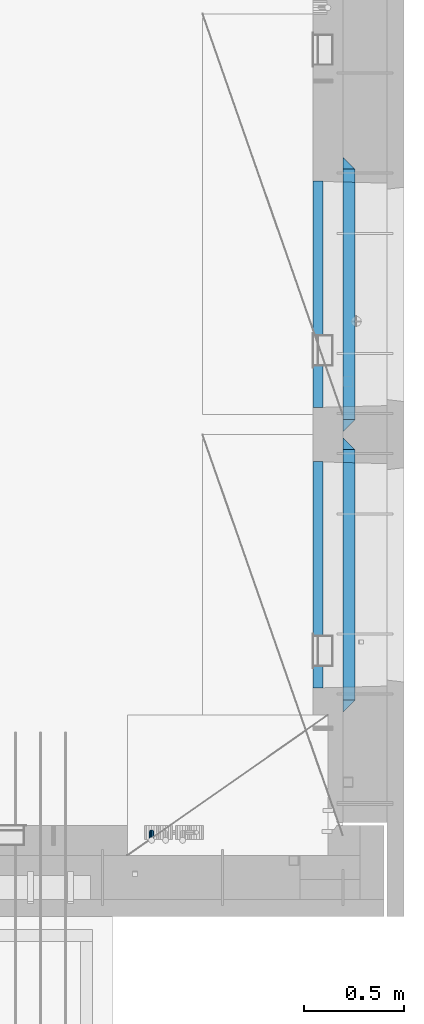
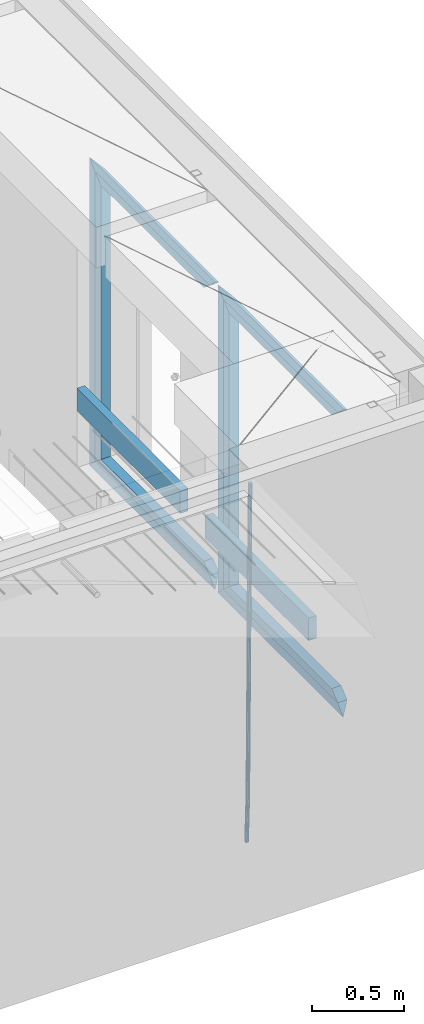
# One storey, part 131 of 350: 15 beams, 2 elements without a shape of their own.
"""IFC2X3 building model written with IfcOpenShell, lengths in millimetres."""

from ifc_helpers import new_model, si_unit, frame, origin_with_axes, place, context, subcontext, project, spatial, faceted_brep, material, type_object, element, aggregate, save


model = new_model("IFC2X3")

# Units and contexts
model_context = context("Model", 3, precision=1e-05, world=origin_with_axes())
body_context = subcontext(model_context, "Body", "Model", "MODEL_VIEW")
ifc_project = project(units=[si_unit("LENGTHUNIT", "METRE", prefix="MILLI"), si_unit("AREAUNIT", "SQUARE_METRE"), si_unit("VOLUMEUNIT", "CUBIC_METRE"), si_unit("MASSUNIT", "GRAM", prefix="KILO"), si_unit("TIMEUNIT", "SECOND"), si_unit("PLANEANGLEUNIT", "RADIAN"), si_unit("SOLIDANGLEUNIT", "STERADIAN"), si_unit("THERMODYNAMICTEMPERATUREUNIT", "DEGREE_CELSIUS"), si_unit("LUMINOUSINTENSITYUNIT", "LUMEN")], contexts=[model_context])

# Site, building, storey
site_placement = place(None, origin_with_axes())
site = spatial("IfcSite", under=ifc_project, at=site_placement, CompositionType="ELEMENT")
building_placement = place(site_placement, origin_with_axes())
building = spatial("IfcBuilding", under=site, at=building_placement, CompositionType="ELEMENT")
storey_placement = place(building_placement, origin_with_axes())
storey = spatial("IfcBuildingStorey", under=building, at=storey_placement, Name="2", CompositionType="ELEMENT", Elevation=0.0)

# Assembly, beam
assembly_1_placement = place(storey_placement, origin_with_axes())
assembly_1 = element("IfcElementAssembly", 1, at=assembly_1_placement, inside=storey, AssemblyPlace="NOTDEFINED", PredefinedType="REINFORCEMENT_UNIT")
ifc_material_1 = material()
beam_type_1 = type_object("IfcBeamType", Name="D25", PredefinedType="NOTDEFINED")
beam_1_placement = place(assembly_1_placement, frame((34104.9999999961, 7965.00000227913, 84990.0), z_axis=(0.00020576299992186, -0.999642804629538, -0.0267249099901004), x_axis=(-4.30000201928125e-08, -0.0267249099948059, 0.999642825806181)))
beam_1 = element("IfcBeam", 2, at=beam_1_placement, type_object=beam_type_1, material=ifc_material_1, Name="JM25", ObjectType="D25", context=body_context, shape_type="Brep", body=[
    faceted_brep([(-7.41420080885291e-08, -12.5, -3.63797880709171e-12), (-6.42030499875546e-08, -10.8253175473074, -6.25000000000364), (60.4103898235917, -10.8253175318459, -6.2499999938409), (60.4103898269532, -12.4999999845422, 6.16273609921336e-09), (-3.70782800018787e-08, -6.25000000000364, -10.8253175473074), (60.4103898202884, -6.24999998454587, -10.8253175411446), (-1.45519152283669e-11, -3.63797880709171e-12, -12.5), (60.4103898179019, 1.54577719513327e-08, -12.4999999938373), (3.70637280866504e-08, 6.25, -10.8253175473074), (60.410389817087, 6.25000001545777, -10.825317541141), (6.42030499875546e-08, 10.8253175473001, -6.25000000000364), (60.410389818062, 10.8253175627578, -6.24999999383726), (7.41420080885291e-08, 12.4999999999927, 0.0), (60.4103898205503, 12.5000000154541, 6.16273609921336e-09), (6.42176019027829e-08, 10.8253175473001, 6.24999999999636), (60.4103898238973, 10.8253175627651, 6.2500000061591), (3.70928319171071e-08, 6.24999999999636, 10.8253175473037), (60.4103898272151, 6.25000001546141, 10.8253175534664), (1.45519152283669e-11, -3.63797880709171e-12, 12.4999999999964), (60.4103898296162, 1.54541339725256e-08, 12.5000000061591), (-3.7049176171422e-08, -6.25000000000364, 10.8253175473001), (60.4103898304165, -6.24999998454587, 10.8253175534701), (-6.41884980723262e-08, -10.8253175473074, 6.25), (60.4103898294561, -10.8253175318459, 6.25000000616637), (61.0324985728803, -10.8253175316895, -6.24999999377542), (60.991802792938, -12.4999999843931, 6.22458173893392e-09), (61.0622854283865, -6.24999998437852, -10.8253175410755), (61.0731819955545, 1.5628756955266e-08, -12.4999999937718), (61.0622685480339, 6.25000001562512, -10.8253175410791), (61.032469335245, 10.8253175629216, -6.24999999377178), (60.9917690322181, 12.5000000156033, 6.22458173893392e-09), (60.9510732522613, 10.8253175629034, 6.25000000621731), (60.9212863967696, 6.25000001558874, 10.8253175535247), (60.9103898296162, 1.55814632307738e-08, 12.5000000062137), (60.9213032771368, -6.24999998441126, 10.8253175535174), (60.9511024898966, -10.8253175317113, 6.25000000621731), (61.6545545670233, -10.8253158516927, -6.24189838219536), (61.573166454793, -12.499998414296, 0.00757164385504439), (61.7141257553885, -6.24999822394238, -10.8168280205282), (61.7359179680789, 1.80548886419274e-06, -12.491368569139), (61.7140919992817, 6.25000177601396, -10.8168282403167), (61.6544960997562, 10.8253192428383, -6.2418987628771), (61.5730989426083, 12.5000015856094, 0.0075712042817031), (61.4917108303925, 10.8253190230062, 6.25704123032847), (61.4321396420273, 6.25000139525582, 10.8319708686649), (61.4103474293224, 1.36582457344048e-06, 12.5065114172721), (61.4321733981196, -6.24999860470052, 10.8319710884571), (61.4917692976451, -10.8253160715249, 6.25704161101385), (176.524302641745, -10.8250056210964, -4.74584321979273), (176.442914529529, -12.4996881836996, 1.50362680625403), (176.583873830095, -6.24968799334965, -9.3207728581292), (176.605666042786, 0.000312036081595579, -10.9953134067364), (176.583840074018, 6.25031200660669, -9.32077307791769), (176.524244174492, 10.8256294734347, -4.74584360047811), (176.44284701733, 12.5003118162058, 1.50362636668069), (176.361458905099, 10.8256292535989, 7.75309639272746), (176.301887716749, 6.25031162585219, 12.3280260310676), (176.280095504058, 0.000311596420942806, 14.0025665796711), (176.301921472827, -6.24968837410415, 12.3280262508561), (176.361517372367, -10.8250058409321, 7.75309677341284), (177.085397012124, -10.8250041057399, -4.73853556792164), (176.983633547483, -12.4996867233749, 1.51066909103247), (177.159881729676, -6.24968643771717, -9.31327097355097), (177.187129580227, 0.000313606451527448, -10.987740468332), (177.159839524218, 6.25031356221734, -9.31327130338468), (177.085323910098, 10.8256309887511, -4.73853613920801), (176.983549136537, 12.5003132764905, 1.51066843136869), (176.881785671867, 10.8256306588555, 7.7598730903228), (176.80730095433, 6.25031299082912, 12.3346084959521), (176.780053103794, 0.000312946667690994, 14.0090779907332), (176.807343159802, -6.2496870091054, 12.3346088257895), (176.881858773908, -10.8250044356355, 7.7598736616128), (177.646431799818, -10.8250018318176, -4.72756919822132), (177.524295146417, -12.4996845320202, 1.52123723245313), (177.735828462886, -6.24968410334986, -9.30201312475765), (177.768531371941, 0.00031596292683389, -10.9763759912421), (177.735777808921, 6.25031589654827, -9.30201361973741), (177.646344064575, 10.8256332626152, -4.72757005553649), (177.524193838486, 12.5003154677688, 1.52123624250817), (177.402057185071, 10.8256327675663, 7.77004267317898), (177.312660521988, 6.2503150390985, 12.3444865997226), (177.279957612933, 0.00031497282179771, 14.0188494661961), (177.312711175953, -6.24968496079964, 12.3444870946951), (177.402144920314, -10.8250023268702, 7.77004353049415), (299.377443161706, -10.8245084454466, -2.34813158632096), (299.255306508276, -12.4991911456491, 3.90067484435349), (299.466839824803, -6.24919071697514, -6.92257551286093), (299.499542733873, 0.0008093492979242, -8.59693837933446), (299.466789170867, 6.250809282923, -6.92257600783341), (299.377355426492, 10.8261266489935, -2.34813244364341), (299.255205200388, 12.5008088541435, 3.90067385440125), (299.133068546944, 10.826126153941, 10.1494802850757), (299.043671883861, 6.25080842546959, 14.7239242116229), (299.010968974762, 0.000808359200163977, 16.3982870780892), (299.043722537797, -6.24919157442127, 14.7239247065918), (299.133156282158, -10.8245089404954, 10.1494811423981), (299.98561436501, -10.8245059804758, -2.33624385599614), (299.97179243555, -12.4991882411778, 3.91467976726199), (299.995742293278, -6.24918857328521, -6.91223722345239), (299.999447243041, 0.000811375455668895, -8.58716690387519), (299.995736475976, 6.25081142679483, -6.91223684201032), (299.985604289133, 10.8261291142808, -2.33624319533556), (299.971750386685, 12.5008117588586, 3.91467993563856), (299.957928457196, 10.8261294971744, 10.1656035610831), (299.947800528913, 6.25081208998381, 14.7415969285394), (299.944095579151, 0.00081214124293183, 16.4165266089549), (299.947806346216, -6.24918791008895, 14.7415965471009), (299.957938533058, -10.8245055975785, 10.1656029004225), (300.593832239858, -10.8245078794353, -2.34543881707941), (300.688302931099, -12.4991904788549, 3.90384712594823), (300.524685350189, -6.24919022474205, -6.92023371784308), (300.499390115292, 0.000809814544481924, -8.59472497713432), (300.524724372954, 6.25080977519247, -6.92023401429469), (300.593899829313, 10.8261272150703, -2.34543933054374), (300.688380976673, 12.5008095210287, 3.90384653304136), (300.782851667915, 10.8261269216127, 10.1531324760799), (300.851998557599, 6.25080926691589, 14.7279273768363), (300.877293792495, 0.000809227632998955, 16.4024186361276), (300.851959534804, -6.24919073302226, 14.7279276732806), (300.782784078474, -10.8245081728965, 10.153132989537), (2293.32930409742, -10.8307295605009, -32.4713622331001), (2293.42377478865, -12.5054121599169, -26.2220762900724), (2293.26015720774, -6.2554119058077, -37.0461571338565), (2293.23486197284, -0.00541186651753378, -38.7206483931477), (2293.26019623051, 6.24458809413409, -37.0461574303008), (2293.32937168686, 10.8199055340046, -32.4713627465644), (2293.42385283421, 12.4945878399631, -26.2220768829684), (2293.51832352545, 10.8199052405434, -19.972790939948), (2293.58747041514, 6.24458758585388, -15.3979960391844), (2293.61276565003, -0.00541245343265473, -13.7235047798931), (2293.58743139236, -6.25541241408428, -15.3979957427327), (2293.51825593603, -10.8307298539585, -19.9727904264691), (2294.0420846676, -10.8307317859326, -32.4821379598216), (2294.03681932652, -12.5054140739521, -26.2313442200393), (2294.06778164886, -6.2554144273563, -37.0583666982457), (2294.10702478497, -0.00541458957013674, -38.7338336404937), (2294.14929890928, 6.24458531819619, -37.0595987724118), (2294.18327670435, 10.8199028679592, -32.4842719748667), (2294.1998538474, 12.4945854171456, -26.2338083683717), (2294.19458850632, 10.819903129126, -19.9830146285858), (2294.16889152506, 6.24458577054975, -15.4067858901581), (2294.12964838895, -0.0054140672327776, -13.7313189479173), (2294.08737426462, -6.2554139749991, -15.4055538159919), (2294.05339646956, -10.8307315247621, -19.9808806135297), (2294.75482297382, -10.84002603931, -32.4726521173216), (2294.64982751427, -12.513407826169, -26.2231856868602), (2294.87535820232, -6.26594539088183, -37.0476186524102), (2294.97913588268, -0.0167870967634371, -38.7222267036377), (2295.0383488692, 6.23299192477134, -37.0477663960555), (2295.03713108998, 10.8087684320271, -32.4729080168181), (2294.97580884799, 12.4844668051373, -26.2234811741473), (2294.87081338844, 10.8110850182784, -19.9740147436787), (2294.7502781599, 6.23700436985018, -15.3990482086047), (2294.64650047956, -0.0121539242718427, -13.7244401573698), (2294.58728749304, -6.26193294580662, -15.3989004649666), (2294.58850527227, -10.8377094530588, -19.9737588441894), (2316.44667268227, -11.1228921988077, -32.1839550346631), (2316.34167722271, -12.7962739856739, -25.9344886042054), (2316.56720791078, -6.54881155039038, -36.7589215697517), (2316.67098559113, -0.299653256264719, -38.4335296209792), (2316.73019857766, 5.95012576527006, -36.759069313397), (2316.72898079845, 10.5259022725259, -32.1842109341669), (2316.66765855643, 12.2016006456361, -25.9347840914961), (2316.56266309689, 10.5282188587698, -19.6853176610275), (2316.44212786836, 5.95413821035254, -15.1103511259389), (2316.33835018802, -0.295020083769487, -13.4357430747186), (2316.27913720149, -6.54479910530426, -15.1102033823008), (2316.28035498071, -11.1205756125637, -19.685061761531), (2317.13234804722, -11.1318335458927, -32.1748293731798), (2317.04181141085, -12.8054038787741, -25.9251705100723), (2317.2154741603, -6.5572650749491, -36.7502937866229), (2317.26891617525, -0.307450393454928, -38.4255717558117), (2317.27835434731, 5.94297770185585, -36.7517739018112), (2317.24125972588, 10.5192220504723, -32.1773930078925), (2317.16757178486, 12.1950816748285, -25.9281307404563), (2317.0770351485, 10.5215113419545, -19.6784718773561), (2316.99390903539, 5.94694287101083, -15.1030074639057), (2316.94046702047, -0.302871810494253, -13.4277294947169), (2316.9310288484, -6.55329990579412, -15.1015273487101), (2316.96812346982, -11.1295442544142, -19.6759082426288), (2317.81808136747, -11.1298054502913, -32.1659056455355), (2317.74200467508, -12.803315894289, -25.9160547315114), (2317.86379538118, -6.55536082026447, -36.7418676070083), (2317.8668976831, -0.305700748642266, -38.417815303761), (2317.82655701396, 5.94458339541234, -36.7446799039099), (2317.75358262347, 10.5207330230332, -32.1707766866384), (2317.66752794063, 12.1965725370646, -25.9216793252963), (2317.59145124823, 10.5230620930706, -19.6718284112721), (2317.54573723453, 5.94861746304377, -15.0958664497994), (2317.54263493262, -0.301042608574789, -13.4199187530394), (2317.58297560175, -6.55132675263303, -15.0930541529051), (2317.65594999224, -11.1274763802539, -19.6669573701693), (2417.81884292323, -10.831603083323, -30.8687911350135), (2417.74276623082, -12.505113527317, -24.618940220982), (2417.86455693691, -6.25715845329614, -35.4447530964935), (2417.86765923884, -0.00749838167394046, -37.1207007932499), (2417.82731856969, 6.24278576237703, -35.4475653933878), (2417.75434417921, 10.8189353900088, -30.8736621761236), (2417.66828949639, 12.494774904033, -24.6245648147851), (2417.59221280397, 10.8212644600353, -18.3747139007501), (2417.54649879028, 6.2468198300121, -13.79875193927), (2417.54339648837, -0.00284024161010166, -12.1228042425173), (2417.5837371575, -6.25312438566107, -13.795939642383), (2417.65671154798, -10.8292740132893, -18.3698428596399)], [[[0, 1, 2, 3]], [[1, 4, 5, 2]], [[4, 6, 7, 5]], [[6, 8, 9, 7]], [[8, 10, 11, 9]], [[10, 12, 13, 11]], [[12, 14, 15, 13]], [[14, 16, 17, 15]], [[16, 18, 19, 17]], [[18, 20, 21, 19]], [[20, 22, 23, 21]], [[22, 0, 3, 23]], [[22, 20, 18, 16, 14, 12, 10, 8, 6, 4, 1, 0]], [[3, 2, 24, 25]], [[2, 5, 26, 24]], [[5, 7, 27, 26]], [[7, 9, 28, 27]], [[9, 11, 29, 28]], [[11, 13, 30, 29]], [[13, 15, 31, 30]], [[15, 17, 32, 31]], [[17, 19, 33, 32]], [[19, 21, 34, 33]], [[21, 23, 35, 34]], [[23, 3, 25, 35]], [[25, 24, 36, 37]], [[24, 26, 38, 36]], [[26, 27, 39, 38]], [[27, 28, 40, 39]], [[28, 29, 41, 40]], [[29, 30, 42, 41]], [[30, 31, 43, 42]], [[31, 32, 44, 43]], [[32, 33, 45, 44]], [[33, 34, 46, 45]], [[34, 35, 47, 46]], [[35, 25, 37, 47]], [[37, 36, 48, 49]], [[36, 38, 50, 48]], [[38, 39, 51, 50]], [[39, 40, 52, 51]], [[40, 41, 53, 52]], [[41, 42, 54, 53]], [[42, 43, 55, 54]], [[43, 44, 56, 55]], [[44, 45, 57, 56]], [[45, 46, 58, 57]], [[46, 47, 59, 58]], [[47, 37, 49, 59]], [[49, 48, 60, 61]], [[48, 50, 62, 60]], [[50, 51, 63, 62]], [[51, 52, 64, 63]], [[52, 53, 65, 64]], [[53, 54, 66, 65]], [[54, 55, 67, 66]], [[55, 56, 68, 67]], [[56, 57, 69, 68]], [[57, 58, 70, 69]], [[58, 59, 71, 70]], [[59, 49, 61, 71]], [[61, 60, 72, 73]], [[60, 62, 74, 72]], [[62, 63, 75, 74]], [[63, 64, 76, 75]], [[64, 65, 77, 76]], [[65, 66, 78, 77]], [[66, 67, 79, 78]], [[67, 68, 80, 79]], [[68, 69, 81, 80]], [[69, 70, 82, 81]], [[70, 71, 83, 82]], [[71, 61, 73, 83]], [[73, 72, 84, 85]], [[72, 74, 86, 84]], [[74, 75, 87, 86]], [[75, 76, 88, 87]], [[76, 77, 89, 88]], [[77, 78, 90, 89]], [[78, 79, 91, 90]], [[79, 80, 92, 91]], [[80, 81, 93, 92]], [[81, 82, 94, 93]], [[82, 83, 95, 94]], [[83, 73, 85, 95]], [[85, 84, 96, 97]], [[84, 86, 98, 96]], [[86, 87, 99, 98]], [[87, 88, 100, 99]], [[88, 89, 101, 100]], [[89, 90, 102, 101]], [[90, 91, 103, 102]], [[91, 92, 104, 103]], [[92, 93, 105, 104]], [[93, 94, 106, 105]], [[94, 95, 107, 106]], [[95, 85, 97, 107]], [[97, 96, 108, 109]], [[96, 98, 110, 108]], [[98, 99, 111, 110]], [[99, 100, 112, 111]], [[100, 101, 113, 112]], [[101, 102, 114, 113]], [[102, 103, 115, 114]], [[103, 104, 116, 115]], [[104, 105, 117, 116]], [[105, 106, 118, 117]], [[106, 107, 119, 118]], [[107, 97, 109, 119]], [[109, 108, 120, 121]], [[108, 110, 122, 120]], [[110, 111, 123, 122]], [[111, 112, 124, 123]], [[112, 113, 125, 124]], [[113, 114, 126, 125]], [[114, 115, 127, 126]], [[115, 116, 128, 127]], [[116, 117, 129, 128]], [[117, 118, 130, 129]], [[118, 119, 131, 130]], [[119, 109, 121, 131]], [[121, 120, 132, 133]], [[120, 122, 134, 132]], [[122, 123, 135, 134]], [[123, 124, 136, 135]], [[124, 125, 137, 136]], [[125, 126, 138, 137]], [[126, 127, 139, 138]], [[127, 128, 140, 139]], [[128, 129, 141, 140]], [[129, 130, 142, 141]], [[130, 131, 143, 142]], [[131, 121, 133, 143]], [[133, 132, 144, 145]], [[132, 134, 146, 144]], [[134, 135, 147, 146]], [[135, 136, 148, 147]], [[136, 137, 149, 148]], [[137, 138, 150, 149]], [[138, 139, 151, 150]], [[139, 140, 152, 151]], [[140, 141, 153, 152]], [[141, 142, 154, 153]], [[142, 143, 155, 154]], [[143, 133, 145, 155]], [[145, 144, 156, 157]], [[144, 146, 158, 156]], [[146, 147, 159, 158]], [[147, 148, 160, 159]], [[148, 149, 161, 160]], [[149, 150, 162, 161]], [[150, 151, 163, 162]], [[151, 152, 164, 163]], [[152, 153, 165, 164]], [[153, 154, 166, 165]], [[154, 155, 167, 166]], [[155, 145, 157, 167]], [[157, 156, 168, 169]], [[156, 158, 170, 168]], [[158, 159, 171, 170]], [[159, 160, 172, 171]], [[160, 161, 173, 172]], [[161, 162, 174, 173]], [[162, 163, 175, 174]], [[163, 164, 176, 175]], [[164, 165, 177, 176]], [[165, 166, 178, 177]], [[166, 167, 179, 178]], [[167, 157, 169, 179]], [[169, 168, 180, 181]], [[168, 170, 182, 180]], [[170, 171, 183, 182]], [[171, 172, 184, 183]], [[172, 173, 185, 184]], [[173, 174, 186, 185]], [[174, 175, 187, 186]], [[175, 176, 188, 187]], [[176, 177, 189, 188]], [[177, 178, 190, 189]], [[178, 179, 191, 190]], [[179, 169, 181, 191]], [[181, 180, 192, 193]], [[180, 182, 194, 192]], [[182, 183, 195, 194]], [[183, 184, 196, 195]], [[184, 185, 197, 196]], [[185, 186, 198, 197]], [[186, 187, 199, 198]], [[187, 188, 200, 199]], [[188, 189, 201, 200]], [[189, 190, 202, 201]], [[190, 191, 203, 202]], [[191, 181, 193, 203]], [[194, 195, 196, 197, 198, 199, 200, 201, 202, 203, 193, 192]]]),
])
aggregate(assembly_1, [beam_1])

# Assembly, beams
assembly_2_placement = place(storey_placement, origin_with_axes())
assembly_2 = element("IfcElementAssembly", 3, at=assembly_2_placement, inside=storey, AssemblyPlace="NOTDEFINED", PredefinedType="REINFORCEMENT_UNIT")
ifc_material_2 = material(Name="TIMBER/T24")
beam_type_2 = type_object("IfcBeamType", PredefinedType="NOTDEFINED")
beam_2_placement = place(assembly_2_placement, frame((34935.0002758707, 8685.00118845241, 85685.0), z_axis=(0.0, 0.0, 1.0), x_axis=(0.0, 1.0, 0.0)))
beam_2 = element("IfcBeam", 4, at=beam_2_placement, type_object=beam_type_2, material=ifc_material_2, context=body_context, shape_type="Brep", body=[
    faceted_brep([(-3.63797880709171e-12, 24.9999999999964, -75.0), (-3.63797880709171e-12, 24.9999999999964, 75.0), (1130.0, 25.0, 75.0), (1130.0, 25.0, -75.0), (0.0, -25.0000000000073, 75.0), (1130.0, -25.0, 75.0), (0.0, -25.0000000000073, -75.0), (1130.0, -25.0, -75.0)], [[[0, 1, 2, 3]], [[1, 4, 5, 2]], [[4, 6, 7, 5]], [[6, 0, 3, 7]], [[5, 7, 3, 2]], [[6, 4, 1, 0]]]),
])
beam_3_placement = place(assembly_2_placement, frame((34935.0002758707, 10085.0011884524, 85685.0), z_axis=(0.0, 0.0, 1.0), x_axis=(0.0, 1.0, 0.0)))
beam_3 = element("IfcBeam", 5, at=beam_3_placement, type_object=beam_type_2, material=ifc_material_2, context=body_context, shape_type="Brep", body=[
    faceted_brep([(-3.63797880709171e-12, 24.9999999999964, -75.0), (-3.63797880709171e-12, 24.9999999999964, 75.0), (1130.0, 25.0, 75.0), (1130.0, 25.0, -75.0), (0.0, -25.0000000000073, 75.0), (1130.0, -25.0, 75.0), (0.0, -25.0000000000073, -75.0), (1130.0, -25.0, -75.0)], [[[0, 1, 2, 3]], [[1, 4, 5, 2]], [[4, 6, 7, 5]], [[6, 0, 3, 7]], [[5, 7, 3, 2]], [[6, 4, 1, 0]]]),
])
ifc_material_3 = material(Name="CONCRETE/C25/30")
beam_type_3 = type_object("IfcBeamType", PredefinedType="NOTDEFINED")
beam_4_placement = place(assembly_2_placement, frame((35090.0, 8565.0001381367, 87145.0), z_axis=(0.0, 0.0, -1.0), x_axis=(0.0, 1.0, 0.0)))
beam_4 = element("IfcBeam", 6, at=beam_4_placement, type_object=beam_type_3, material=ifc_material_3, Name="SK", context=body_context, shape_type="Brep", body=[
    faceted_brep([(60.0000000000073, 30.0, 30.0), (0.0, -30.0, -30.0), (60.0000000000073, -30.0, 30.0), (1309.99990463256, 30.0, 30.0), (1369.99990463257, -30.0, -30.0), (1309.99990463256, -30.0, 30.0)], [[[0, 1, 2]], [[1, 0, 3, 4]], [[2, 1, 4, 5]], [[0, 2, 5, 3]], [[4, 3, 5]]]),
])
beam_5_placement = place(assembly_2_placement, frame((35090.0, 8625.0001381367, 87085.0), z_axis=(0.0, 0.0, -1.0), x_axis=(0.0, 1.0, 0.0)))
beam_5 = element("IfcBeam", 7, at=beam_5_placement, type_object=beam_type_3, material=ifc_material_3, Name="SK", context=body_context, shape_type="Brep", body=[
    faceted_brep([(65.6755803082433, 30.0, 25.6756756756804), (64.0539586866216, -30.0, 24.0540540540533), (1185.94585057852, -30.0, 24.0540540540533), (1184.32422895689, 30.0, 25.6756756756804), (65.6755803082433, 30.0, 26.2933545375708), (64.0539586866216, -30.0, 24.9033931479062), (0.0, -30.0, -30.0), (0.0, 30.0, -30.0), (1249.99990463257, 30.0, -30.0), (1249.99990463257, -30.0, -30.0), (1185.94585057852, -30.0, 24.9034748914273), (1184.32422895689, 30.0, 26.293436281092)], [[[0, 1, 2, 3]], [[1, 0, 4, 5]], [[6, 5, 4, 7]], [[6, 7, 8, 9]], [[2, 1, 5, 6, 9, 10]], [[3, 2, 10, 11]], [[7, 4, 0, 3, 11, 8]], [[10, 9, 8, 11]]]),
])
beam_6_placement = place(assembly_2_placement, frame((35090.0, 9905.00004276927, 87175.0), z_axis=(0.0, -1.0, 0.0), x_axis=(0.0, 0.0, -1.0)))
beam_6 = element("IfcBeam", 8, at=beam_6_placement, type_object=beam_type_3, material=ifc_material_3, Name="SK", context=body_context, shape_type="Brep", body=[
    faceted_brep([(60.0000000000073, 30.0, 30.0), (0.0, -30.0, -30.0), (60.0000000000073, -30.0, 30.0), (1995.0, 30.0, 30.0), (2055.0, -30.0, -30.0), (1995.0, -30.0, 30.0)], [[[0, 1, 2]], [[3, 4, 1, 0]], [[4, 5, 2, 1]], [[5, 3, 0, 2]], [[5, 4, 3]]]),
])
beam_7_placement = place(assembly_2_placement, frame((35090.0, 9875.00004276927, 85210.0), z_axis=(0.0, 0.0, 1.0), x_axis=(0.0, -1.0, 0.0)))
beam_7 = element("IfcBeam", 9, at=beam_7_placement, type_object=beam_type_3, material=ifc_material_3, Name="SK", context=body_context, shape_type="Brep", body=[
    faceted_brep([(1185.94594588314, -29.9999988381387, 24.0540541168593), (1184.32432432432, 29.9999988381387, 25.6756756756804), (65.6756756756768, 30.0, 25.6756756756804), (64.0540540540533, -30.0, 24.0540540540533), (1185.94594594595, -30.0, 24.9033931479207), (1184.32432432433, 30.0, 26.2933545375854), (1249.99990463257, -30.0, -30.0), (1249.99990463257, 30.0, -30.0), (0.0, 30.0, -30.0), (65.6756756756768, 30.0, 26.293436281092), (64.0540540540533, -30.0, 24.9034748914419), (0.0, -30.0, -30.0)], [[[0, 1, 2, 3]], [[1, 0, 4, 5]], [[6, 7, 5, 4]], [[2, 1, 5, 7, 8, 9]], [[3, 2, 9, 10]], [[6, 4, 0, 3, 10, 11]], [[11, 8, 7, 6]], [[11, 10, 9, 8]]]),
])
beam_8_placement = place(assembly_2_placement, frame((35090.0, 9935.00004276927, 85150.0), z_axis=(0.0, 0.0, 1.0), x_axis=(0.0, -1.0, 0.0)))
beam_8 = element("IfcBeam", 10, at=beam_8_placement, type_object=beam_type_3, material=ifc_material_3, Name="SK", context=body_context, shape_type="Brep", body=[
    faceted_brep([(1369.99990463257, -30.0, -30.0), (1309.99990463256, 30.0, 30.0), (1309.99990463256, -30.0, 30.0), (60.0000000000073, 30.0, 30.0), (60.0000000000073, -30.0, 30.0), (0.0, -30.0, -30.0)], [[[0, 1, 2]], [[3, 4, 2, 1]], [[4, 5, 0, 2]], [[5, 3, 1, 0]], [[3, 5, 4]]]),
])
beam_9_placement = place(assembly_2_placement, frame((35090.0, 9965.00023350414, 87145.0), z_axis=(0.0, 0.0, -1.0), x_axis=(0.0, 1.0, 0.0)))
beam_9 = element("IfcBeam", 11, at=beam_9_placement, type_object=beam_type_3, material=ifc_material_3, Name="SK", context=body_context, shape_type="Brep", body=[
    faceted_brep([(60.0000000000073, 30.0, 30.0), (0.0, -30.0, -30.0), (60.0000000000073, -30.0, 30.0), (1309.99942779541, 30.0, 30.0), (1369.99942779541, -30.0, -30.0), (1309.99942779541, -30.0, 30.0)], [[[0, 1, 2]], [[1, 0, 3, 4]], [[2, 1, 4, 5]], [[0, 2, 5, 3]], [[4, 3, 5]]]),
])
beam_10_placement = place(assembly_2_placement, frame((35090.0, 10025.0002335041, 87085.0), z_axis=(0.0, 0.0, -1.0), x_axis=(0.0, 1.0, 0.0)))
beam_10 = element("IfcBeam", 12, at=beam_10_placement, type_object=beam_type_3, material=ifc_material_3, Name="SK", context=body_context, shape_type="Brep", body=[
    faceted_brep([(65.6751034710851, 30.0, 25.6756756756804), (64.0534818494634, -30.0, 24.0540540540533), (1185.94537374136, -30.0, 24.0540540540533), (1184.32375211974, 30.0, 25.6756756756804), (65.6751034710851, 30.0, 26.2929458199942), (64.0534818494634, -30.0, 24.9029844303586), (0.0, -30.0, -30.0), (0.0, 30.0, -30.0), (1249.99942779541, 30.0, -30.0), (1249.99942779541, -30.0, -30.0), (1185.94537374136, -30.0, 24.9034748914273), (1184.32375211974, 30.0, 26.293436281092)], [[[0, 1, 2, 3]], [[1, 0, 4, 5]], [[6, 5, 4, 7]], [[6, 7, 8, 9]], [[2, 1, 5, 6, 9, 10]], [[3, 2, 10, 11]], [[7, 4, 0, 3, 11, 8]], [[10, 9, 8, 11]]]),
])
beam_11_placement = place(assembly_2_placement, frame((35090.0, 11304.9996612995, 87175.0), z_axis=(0.0, -1.0, 0.0), x_axis=(0.0, 0.0, -1.0)))
beam_11 = element("IfcBeam", 13, at=beam_11_placement, type_object=beam_type_3, material=ifc_material_3, Name="SK", context=body_context, shape_type="Brep", body=[
    faceted_brep([(60.0000000000073, 30.0, 30.0), (0.0, -30.0, -30.0), (60.0000000000073, -30.0, 30.0), (1995.0, 30.0, 30.0), (2055.0, -30.0, -30.0), (1995.0, -30.0, 30.0)], [[[0, 1, 2]], [[3, 4, 1, 0]], [[4, 5, 2, 1]], [[5, 3, 0, 2]], [[5, 4, 3]]]),
])
beam_12_placement = place(assembly_2_placement, frame((35090.0, 11274.9996612995, 85210.0), z_axis=(0.0, 0.0, 1.0), x_axis=(0.0, -1.0, 0.0)))
beam_12 = element("IfcBeam", 14, at=beam_12_placement, type_object=beam_type_3, material=ifc_material_3, Name="SK", context=body_context, shape_type="Brep", body=[
    faceted_brep([(1185.94594588314, -29.9999988381387, 24.0540541168593), (1184.32432432432, 29.9999988381387, 25.6756756756804), (65.6756756756768, 30.0, 25.6756756756804), (64.0540540540533, -30.0, 24.0540540540533), (1185.94594594595, -30.0, 24.9029844303586), (1184.32432432433, 30.0, 26.2929458200088), (1249.99942779541, -30.0, -30.0), (1249.99942779541, 30.0, -30.0), (0.0, 30.0, -30.0), (65.6756756756768, 30.0, 26.293436281092), (64.0540540540533, -30.0, 24.9034748914419), (0.0, -30.0, -30.0)], [[[0, 1, 2, 3]], [[1, 0, 4, 5]], [[6, 7, 5, 4]], [[2, 1, 5, 7, 8, 9]], [[3, 2, 9, 10]], [[6, 4, 0, 3, 10, 11]], [[11, 8, 7, 6]], [[11, 10, 9, 8]]]),
])
beam_13_placement = place(assembly_2_placement, frame((35090.0, 11334.9996612995, 85150.0), z_axis=(0.0, 0.0, 1.0), x_axis=(0.0, -1.0, 0.0)))
beam_13 = element("IfcBeam", 15, at=beam_13_placement, type_object=beam_type_3, material=ifc_material_3, Name="SK", context=body_context, shape_type="Brep", body=[
    faceted_brep([(1369.99942779541, -30.0, -30.0), (1309.99942779541, 30.0, 30.0), (1309.99942779541, -30.0, 30.0), (60.0000000000073, 30.0, 30.0), (60.0000000000073, -30.0, 30.0), (0.0, -30.0, -30.0)], [[[0, 1, 2]], [[3, 4, 2, 1]], [[4, 5, 0, 2]], [[5, 3, 1, 0]], [[3, 5, 4]]]),
])
beam_type_4 = type_object("IfcBeamType", PredefinedType="NOTDEFINED")
beam_14_placement = place(assembly_2_placement, frame((35090.0, 9840.00004276927, 87115.0), z_axis=(0.0, -1.0, 0.0), x_axis=(0.0, 0.0, -1.0)))
beam_14 = element("IfcBeam", 16, at=beam_14_placement, type_object=beam_type_4, material=ifc_material_3, Name="SK", context=body_context, shape_type="Brep", body=[
    faceted_brep([(0.0, -30.0, -35.0), (54.9034748914273, -30.0, 29.0540540540533), (56.2934362811066, 30.0, 30.6756756756768), (0.0, 30.0, -35.0), (1935.0, 30.0, -35.0), (1935.0, -30.0, -35.0), (1880.09652510857, -30.0, 29.0540540540533), (1878.70656371891, 30.0, 30.6756756756749)], [[[0, 1, 2, 3]], [[4, 5, 0, 3]], [[1, 0, 5, 6]], [[2, 1, 6, 7]], [[3, 2, 7, 4]], [[6, 5, 4, 7]]]),
])
beam_15_placement = place(assembly_2_placement, frame((35090.0, 11239.9996612995, 87115.0), z_axis=(0.0, -1.0, 0.0), x_axis=(0.0, 0.0, -1.0)))
beam_15 = element("IfcBeam", 17, at=beam_15_placement, type_object=beam_type_4, material=ifc_material_3, Name="SK", context=body_context, shape_type="Brep", body=[
    faceted_brep([(0.0, -30.0, -35.0), (54.9034748914273, -30.0, 29.0540540540533), (56.2934362811066, 30.0, 30.6756756756768), (0.0, 30.0, -35.0), (1935.0, 30.0, -35.0), (1935.0, -30.0, -35.0), (1880.09652510857, -30.0, 29.0540540540533), (1878.70656371891, 30.0, 30.6756756756749)], [[[0, 1, 2, 3]], [[4, 5, 0, 3]], [[1, 0, 5, 6]], [[2, 1, 6, 7]], [[3, 2, 7, 4]], [[6, 5, 4, 7]]]),
])
aggregate(assembly_2, [beam_2, beam_3, beam_4, beam_5, beam_6, beam_14, beam_7, beam_8, beam_9, beam_10, beam_11, beam_15, beam_12, beam_13])

save(model, "model.ifc")
